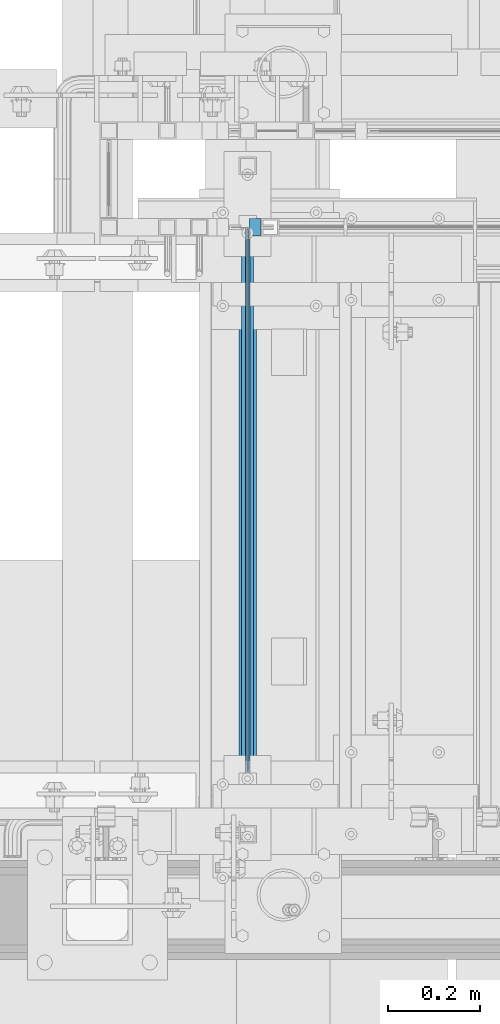
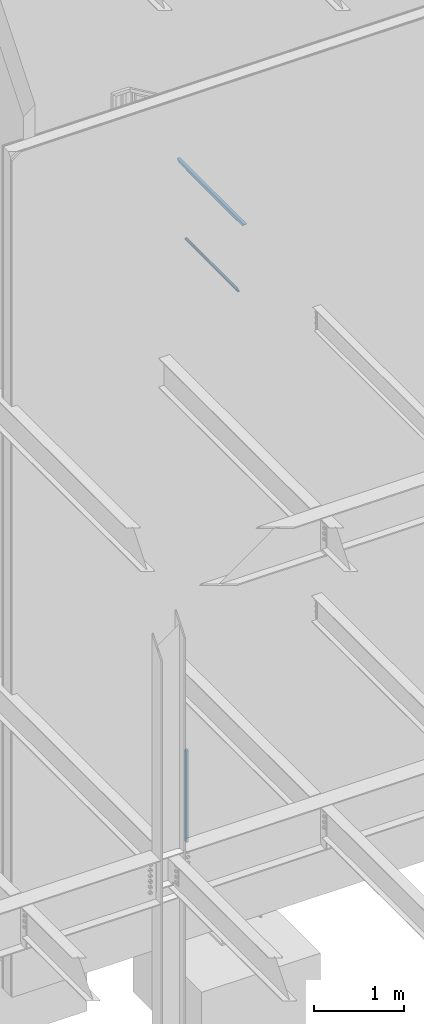
# One storey, part 779 of 1179: 3 members, 2 beams, 2 elements without a shape of their own.
"""IFC2X3 building model written with IfcOpenShell, lengths in millimetres."""

from ifc_helpers import new_model, si_unit, frame, origin_with_axes, place, context, subcontext, project, spatial, faceted_brep, material, type_object, element, aggregate, save


model = new_model("IFC2X3")

# Units and contexts
model_context = context("Model", 3, precision=1e-05, world=origin_with_axes())
body_context = subcontext(model_context, "Body", "Model", "MODEL_VIEW")
ifc_project = project(units=[si_unit("LENGTHUNIT", "METRE", prefix="MILLI"), si_unit("AREAUNIT", "SQUARE_METRE"), si_unit("VOLUMEUNIT", "CUBIC_METRE"), si_unit("MASSUNIT", "GRAM", prefix="KILO"), si_unit("TIMEUNIT", "SECOND"), si_unit("PLANEANGLEUNIT", "RADIAN"), si_unit("SOLIDANGLEUNIT", "STERADIAN"), si_unit("THERMODYNAMICTEMPERATUREUNIT", "DEGREE_CELSIUS"), si_unit("LUMINOUSINTENSITYUNIT", "LUMEN")], contexts=[model_context])

# Site, building, storey
site_placement = place(None, origin_with_axes())
site = spatial("IfcSite", under=ifc_project, at=site_placement, CompositionType="ELEMENT")
building_placement = place(site_placement, origin_with_axes())
building = spatial("IfcBuilding", under=site, at=building_placement, Name="Undefined", CompositionType="ELEMENT")
storey_placement = place(building_placement, origin_with_axes())
storey = spatial("IfcBuildingStorey", under=building, at=storey_placement, Name="Undefined", CompositionType="ELEMENT", Elevation=0.0)

# Assembly, member
assembly_1_placement = place(storey_placement, origin_with_axes())
assembly_1 = element("IfcElementAssembly", 1, at=assembly_1_placement, inside=storey, Name="GUARDRAIL", AssemblyPlace="NOTDEFINED", PredefinedType="RIGID_FRAME")
ifc_material_1 = material(Name="STEEL/A36")
member_type_1 = type_object("IfcMemberType", PredefinedType="NOTDEFINED")
member_1_placement = place(assembly_1_placement, frame((19621.5000005731, 39471.5999999818, 40.8806392036358), z_axis=(0.0, -1.0, 0.0), x_axis=(0.0, 0.0, 1.0)))
member_1 = element("IfcMember", 2, at=member_1_placement, type_object=member_type_1, material=ifc_material_1, Name="POST", context=body_context, shape_type="Brep", body=[
    faceted_brep([(1257.59245954642, -12.7000000000007, 19.0500000000029), (1257.59245954642, -12.7000000000007, -19.0500000000029), (1242.88603593101, 12.7000000000007, -19.0500000000029), (1242.88603593101, 12.7000000000007, 19.0500000000029), (0.0, -12.7000000000007, -19.0500000000029), (0.0, -12.7000000000007, 19.0500000000029), (0.0, 12.7000000000007, 19.0500000000029), (0.0, 12.7000000000007, -19.0500000000029)], [[[0, 1, 2, 3]], [[4, 5, 6, 7]], [[6, 5, 0, 3]], [[7, 6, 3, 2]], [[4, 7, 2, 1]], [[5, 4, 1, 0]]]),
])
aggregate(assembly_1, [member_1])

# Assembly, beams, members
assembly_2_placement = place(storey_placement, origin_with_axes())
assembly_2 = element("IfcElementAssembly", 3, at=assembly_2_placement, inside=storey, Name="GUARDRAIL", AssemblyPlace="NOTDEFINED", PredefinedType="RIGID_FRAME")
ifc_material_2 = material(Name="STEEL/BUY-OUT")
beam_type = type_object("IfcBeamType", PredefinedType="NOTDEFINED")
beam_1_placement = place(assembly_2_placement, frame((19602.4499999015, 38877.8750023459, 9167.81250101082), z_axis=(0.0, 1.0, 0.0), x_axis=(0.0, 0.0, 1.0)))
beam_1 = element("IfcBeam", 4, at=beam_1_placement, type_object=beam_type, material=ifc_material_2, Name="U-EDGE", context=body_context, shape_type="Brep", body=[
    faceted_brep([(0.0, 1.58750000000146, -566.73750244017), (0.0, -1.58750000000146, -566.73750244017), (0.0, -1.58750000000146, 566.737498805735), (0.0, 1.58750000000146, 566.737498805735), (22.2250001107132, 1.58750000000146, -588.962502550887), (22.2250001107132, 1.58750000000146, 588.962499670793), (22.2250002214296, 4.76250000000073, -588.962502661598), (22.2250002214296, 4.76250000000073, 588.962499781512), (3.3215110306628e-07, 4.76250000000073, -566.737502772325), (3.3215110306628e-07, 4.76250000000073, 566.737499137889), (3.3215110306628e-07, 7.93750000000364, -566.737502772325), (3.3215110306628e-07, 7.93750000000364, 566.737499137889), (25.4000003321471, 7.93750000000364, -592.137499999997), (25.4000003321471, 7.93750000000364, 592.137499999997), (25.399999999996, -1.58750000000146, -592.137499999997), (25.399999999996, -1.58750000000146, 592.137499999997)], [[[0, 1, 2, 3]], [[4, 0, 3, 5]], [[6, 4, 5, 7]], [[8, 6, 7, 9]], [[10, 8, 9, 11]], [[12, 10, 11, 13]], [[14, 12, 13, 15]], [[11, 9, 7, 5, 3, 2, 15, 13]], [[1, 14, 15, 2]], [[0, 4, 6, 8, 10, 12, 14, 1]]]),
])
beam_2_placement = place(assembly_2_placement, frame((19602.4499999015, 38877.87499847, 8262.9375024466), z_axis=(0.0, -1.0, 0.0), x_axis=(0.0, 0.0, -1.0)))
beam_2 = element("IfcBeam", 5, at=beam_2_placement, type_object=beam_type, material=ifc_material_2, Name="U-EDGE", context=body_context, shape_type="Brep", body=[
    faceted_brep([(0.0, 1.58750000000146, -566.73750244017), (0.0, -1.58750000000146, -566.73750244017), (0.0, -1.58750000000146, 566.737498805735), (0.0, 1.58750000000146, 566.737498805735), (22.2250001107132, 1.58750000000146, -588.962502550887), (22.2250001107132, 1.58750000000146, 588.962499670793), (22.2250002214296, 4.76250000000073, -588.962502661598), (22.2250002214296, 4.76250000000073, 588.962499781512), (3.3215110306628e-07, 4.76250000000073, -566.737502772325), (3.3215110306628e-07, 4.76250000000073, 566.737499137889), (3.3215110306628e-07, 7.93750000000364, -566.737502772325), (3.3215110306628e-07, 7.93750000000364, 566.737499137889), (25.4000003321471, 7.93750000000364, -592.137499999997), (25.4000003321471, 7.93750000000364, 592.137499999997), (25.399999999996, -1.58750000000146, -592.137499999997), (25.399999999996, -1.58750000000146, 592.137499999997)], [[[0, 1, 2, 3]], [[4, 0, 3, 5]], [[6, 4, 5, 7]], [[8, 6, 7, 9]], [[10, 8, 9, 11]], [[12, 10, 11, 13]], [[14, 12, 13, 15]], [[11, 9, 7, 5, 3, 2, 15, 13]], [[1, 14, 15, 2]], [[0, 4, 6, 8, 10, 12, 14, 1]]]),
])
ifc_material_3 = material()
member_type_2 = type_object("IfcMemberType", Name="HSS1-1/2X1-1/2X1/8", PredefinedType="NOTDEFINED")
member_2_placement = place(assembly_2_placement, frame((19605.6249999269, 38150.799999235, 9213.85000059595), z_axis=(0.0, 0.0, 1.0), x_axis=(0.0, 1.0, 0.0)))
member_2 = element("IfcMember", 6, at=member_2_placement, type_object=member_type_2, material=ifc_material_3, Name="GUARDRAIL", ObjectType="HSS1-1/2X1-1/2X1/8", context=body_context, shape_type="Brep", body=[
    faceted_brep([(15.874999282998, 15.874999282998, -15.8749992829999), (15.874999282998, -15.874999282998, -15.8749992829999), (1438.27500304497, -15.8749992830017, -15.8749992829999), (1438.27500304497, 15.8749992830017, -15.8749992829999), (-15.8749992830017, -15.874999282998, 15.8749992829999), (1470.02500161097, -15.8749992830017, 15.8749992829999), (-15.8749992830017, 15.874999282998, 15.8749992829999), (1470.02500161097, 15.8749992830017, 15.8749992829999), (19.0499999999993, 19.0499992349996, -19.0499992350015), (-19.0499992350015, 19.0499992350015, 19.0499992349996), (1473.20000156297, 19.0499992350015, 19.0499992349996), (1435.10000309296, 19.0499992350015, -19.0499992349996), (-19.0499992350015, -19.0499992350015, 19.0499992349996), (1473.20000156297, -19.0499992350015, 19.0499992349996), (19.0499999999993, -19.0499992349996, -19.0499992350015), (1435.10000309296, -19.0499992350015, -19.0499992349996)], [[[0, 1, 2, 3]], [[1, 4, 5, 2]], [[4, 6, 7, 5]], [[6, 0, 3, 7]], [[8, 9, 10, 11]], [[9, 12, 13, 10]], [[12, 14, 15, 13]], [[14, 8, 11, 15]], [[13, 15, 11, 10], [5, 7, 3, 2]], [[14, 12, 9, 8], [6, 4, 1, 0]]]),
])
member_type_3 = type_object("IfcMemberType", PredefinedType="NOTDEFINED")
member_3_placement = place(assembly_2_placement, frame((19605.6249999015, 38271.44999847, 8229.60000047568), z_axis=(1.0, 0.0, 0.0), x_axis=(0.0, 1.0, 0.0)))
member_3 = element("IfcMember", 7, at=member_3_placement, type_object=member_type_3, material=ifc_material_1, Name="BOTTOM_RAIL", context=body_context, shape_type="Brep", body=[
    faceted_brep([(12.6999999999971, 6.35000000000036, -12.7000000000007), (12.6999999999971, 6.35000000000036, 12.7000000000007), (1200.15000385797, 6.35000000000036, 12.7000000000007), (1200.15000385797, 6.35000000000036, -12.7000000000007), (12.6999999999971, -6.35000000000036, 12.7000000000007), (1200.15000385797, -6.35000000000036, 12.7000000000007), (12.6999999999971, -6.35000000000036, -12.7000000000007), (1200.15000385797, -6.35000000000036, -12.7000000000007)], [[[0, 1, 2, 3]], [[1, 4, 5, 2]], [[4, 6, 7, 5]], [[6, 0, 3, 7]], [[5, 7, 3, 2]], [[6, 4, 1, 0]]]),
])
aggregate(assembly_2, [beam_1, beam_2, member_3, member_2])

save(model, "model.ifc")
